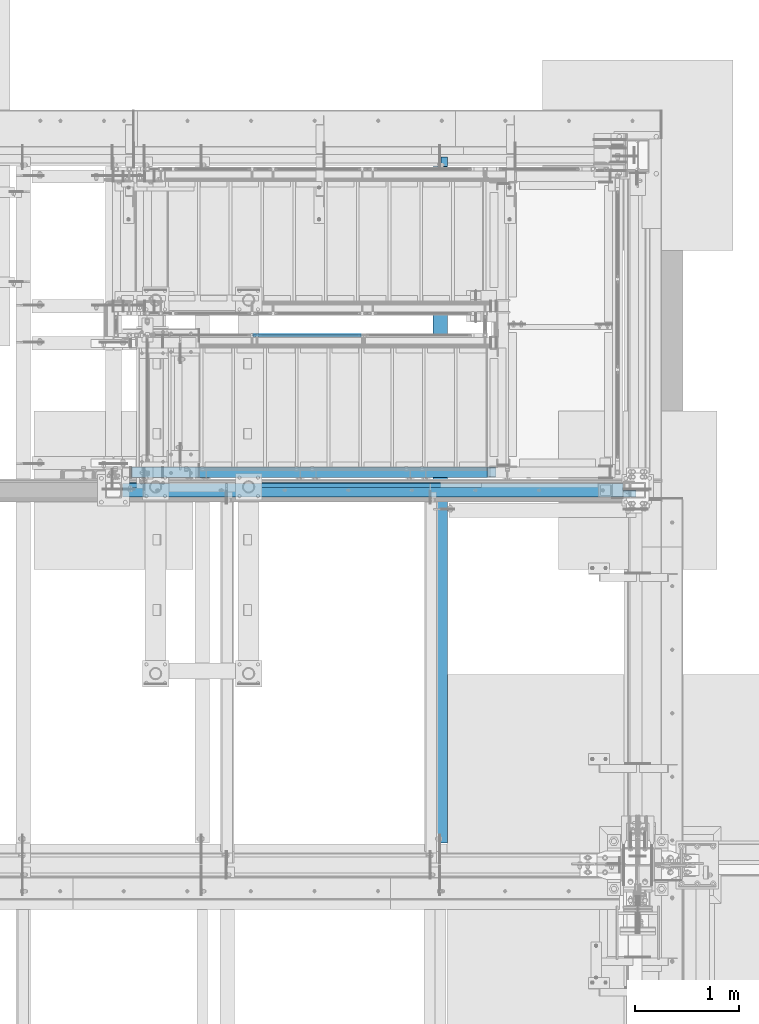
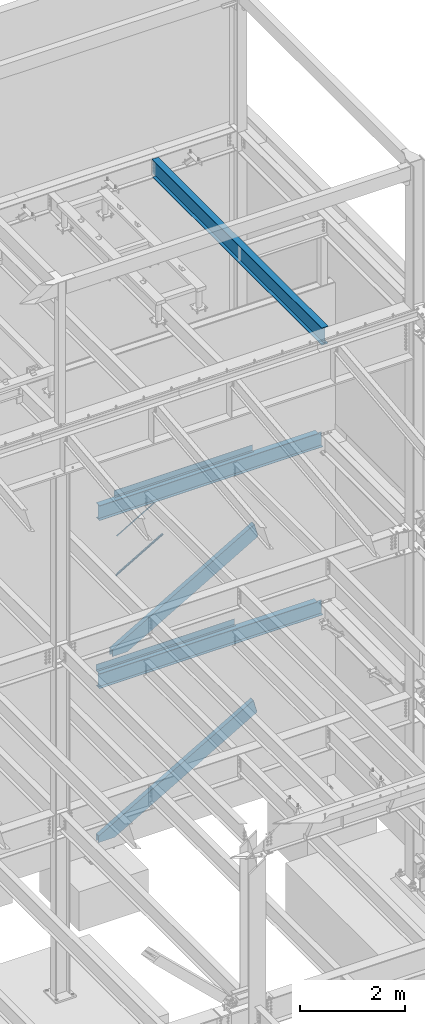
# One storey, part 782 of 1179: 7 beams, 3 members, 6 elements without a shape of their own.
"""IFC2X3 building model written with IfcOpenShell, lengths in millimetres."""

from ifc_helpers import new_model, si_unit, frame, origin_with_axes, place, context, subcontext, project, spatial, faceted_brep, material, type_object, element, aggregate, save


model = new_model("IFC2X3")

# Units and contexts
model_context = context("Model", 3, precision=1e-05, world=origin_with_axes())
body_context = subcontext(model_context, "Body", "Model", "MODEL_VIEW")
ifc_project = project(units=[si_unit("LENGTHUNIT", "METRE", prefix="MILLI"), si_unit("AREAUNIT", "SQUARE_METRE"), si_unit("VOLUMEUNIT", "CUBIC_METRE"), si_unit("MASSUNIT", "GRAM", prefix="KILO"), si_unit("TIMEUNIT", "SECOND"), si_unit("PLANEANGLEUNIT", "RADIAN"), si_unit("SOLIDANGLEUNIT", "STERADIAN"), si_unit("THERMODYNAMICTEMPERATUREUNIT", "DEGREE_CELSIUS"), si_unit("LUMINOUSINTENSITYUNIT", "LUMEN")], contexts=[model_context])

# Site, building, storey
site_placement = place(None, origin_with_axes())
site = spatial("IfcSite", under=ifc_project, at=site_placement, CompositionType="ELEMENT")
building_placement = place(site_placement, origin_with_axes())
building = spatial("IfcBuilding", under=site, at=building_placement, Name="Undefined", CompositionType="ELEMENT")
storey_placement = place(building_placement, origin_with_axes())
storey = spatial("IfcBuildingStorey", under=building, at=storey_placement, Name="Undefined", CompositionType="ELEMENT", Elevation=0.0)

# Assembly, beams, member
assembly_1_placement = place(storey_placement, origin_with_axes())
assembly_1 = element("IfcElementAssembly", 1, at=assembly_1_placement, inside=storey, Name="GUARDRAIL", AssemblyPlace="NOTDEFINED", PredefinedType="RIGID_FRAME")
ifc_material_1 = material(Name="STEEL/BUY-OUT")
beam_type_1 = type_object("IfcBeamType", PredefinedType="NOTDEFINED")
beam_1_placement = place(assembly_1_placement, frame((21150.1497940526, 39468.4251646336, 6211.04381226294), z_axis=(-0.86377890071706, 0.0, -0.503871025835012), x_axis=(-0.503871025835012, 0.0, 0.86377890071706)))
beam_1 = element("IfcBeam", 2, at=beam_1_placement, type_object=beam_type_1, material=ifc_material_1, Name="U-EDGE", context=body_context, shape_type="Brep", body=[
    faceted_brep([(-2.62571120401844e-09, 1.58750000000146, -551.090159790514), (22.2250002407682, 1.58750000000146, -589.784707497234), (22.2250002534201, 4.76249998393178, -589.784707519266), (5.1261577027617e-07, 4.76249998815911, -551.090160687567), (5.1261577027617e-07, 7.93749998815474, -551.090160687567), (25.400000253393, 7.93749998378189, -595.312499999403), (25.4000002406228, -1.58750000000146, -595.312499999232), (-2.62571120401844e-09, -1.58750000000146, -551.090159790514), (25.4000002718667, -1.58750000000146, 595.312499998905), (2.76122591458261e-09, -1.58750000000146, 580.723427522342), (2.76122591458261e-09, 1.58750000000146, 580.723427522342), (22.2250002718201, 1.58750000000146, 593.488867387849), (22.2250002590899, 4.76250001617154, 593.48886738054), (5.1151801017113e-07, 4.76250001247536, 580.723427814559), (5.1151801017113e-07, 7.93750001247827, 580.723427814559), (25.4000002590974, 7.93750001621811, 595.31249999873)], [[[0, 1, 2, 3, 4, 5, 6, 7]], [[7, 6, 8, 9]], [[0, 7, 9, 10]], [[1, 0, 10, 11]], [[2, 1, 11, 12]], [[3, 2, 12, 13]], [[4, 3, 13, 14]], [[5, 4, 14, 15]], [[6, 5, 15, 8]], [[14, 13, 12, 11, 10, 9, 8, 15]]]),
])
beam_2_placement = place(assembly_1_placement, frame((21124.5531730082, 39468.4251646336, 5346.87372905889), z_axis=(-0.86377890071706, 0.0, -0.503871025835012), x_axis=(0.503871110270223, 0.0, -0.863778851463181)))
beam_2 = element("IfcBeam", 3, at=beam_2_placement, type_object=beam_type_1, material=ifc_material_1, Name="U-EDGE", context=body_context, shape_type="Brep", body=[
    faceted_brep([(3.39150574291125e-09, 1.58750000000146, 551.090060740255), (3.39150574291125e-09, -1.58750000000146, 551.090060740255), (22.2249999259266, -1.58750000000146, 589.784086195607), (22.2249999386131, -4.76249998396088, 589.784086217693), (-1.22384335554671e-07, -4.76249998815911, 551.090060521277), (-1.22384335554671e-07, -7.93749998815474, 551.090060521277), (25.3999999386497, -7.93749998381099, 595.312500000691), (25.3999999258431, 1.58750000000146, 595.31250000052), (25.3999999312882, -7.93750001618173, -595.312500000728), (25.3999999440939, 1.58750000000146, -595.312500000899), (-3.57522367266938e-09, 1.58750000000146, -580.72370144297), (-3.57522367266938e-09, -1.58750000000146, -580.72370144297), (22.2249999440628, -1.58750000000146, -593.488900187338), (22.2249999312971, -4.76250001613516, -593.488900180007), (-1.35833943204489e-07, -4.76250001247536, -580.723701367002), (-1.35833943204489e-07, -7.93750001247827, -580.723701367002)], [[[0, 1, 2, 3, 4, 5, 6, 7]], [[7, 6, 8, 9]], [[0, 7, 9, 10]], [[1, 0, 10, 11]], [[2, 1, 11, 12]], [[3, 2, 12, 13]], [[4, 3, 13, 14]], [[5, 4, 14, 15]], [[6, 5, 15, 8]], [[14, 13, 12, 11, 10, 9, 8, 15]]]),
])
ifc_material_2 = material(Name="STEEL/A36")
member_type_1 = type_object("IfcMemberType", PredefinedType="NOTDEFINED")
member_1_placement = place(assembly_1_placement, frame((20608.9249990163, 39471.5999992249, 5006.80119240496), z_axis=(0.0, -1.0, 0.0), x_axis=(0.863778900717086, 0.0, 0.503871025834967)))
member_1 = element("IfcMember", 4, at=member_1_placement, type_object=member_type_1, material=ifc_material_2, Name="BOTTOM_RAIL", context=body_context, shape_type="Brep", body=[
    faceted_brep([(1213.01247515505, 6.34999999891988, 12.6999999999971), (1205.60414181559, -6.3500000010672, 12.6999999999971), (1205.60414181559, -6.3500000010672, -12.6999999999971), (1213.01247515505, 6.34999999891988, -12.6999999999971), (18.4069803798266, 6.34999999998945, 12.6999999999971), (18.4069803798266, 6.34999999998945, -12.6999999999971), (10.9986698027969, -6.35000000000309, -12.6999999999971), (10.9986698027969, -6.35000000000309, 12.6999999999971)], [[[0, 1, 2, 3]], [[4, 5, 6, 7]], [[5, 4, 0, 3]], [[6, 5, 3, 2]], [[7, 6, 2, 1]], [[4, 7, 1, 0]]]),
])
aggregate(assembly_1, [beam_1, beam_2, member_1])

# Assembly, beam
assembly_2_placement = place(storey_placement, origin_with_axes())
assembly_2 = element("IfcElementAssembly", 5, at=assembly_2_placement, inside=storey, Name="BEAM", AssemblyPlace="NOTDEFINED", PredefinedType="RIGID_FRAME")
beam_type_2 = type_object("IfcBeamType", PredefinedType="NOTDEFINED")
beam_3_placement = place(assembly_2_placement, frame((21285.2, 38058.725, 8147.05000610352), z_axis=(1.0, 0.0, 0.0), x_axis=(0.0, 0.0, -1.0)))
beam_3 = element("IfcBeam", 6, at=beam_3_placement, type_object=beam_type_2, material=ifc_material_2, Name="BENT_PLATE", context=body_context, shape_type="Brep", body=[
    faceted_brep([(0.0, -3.17499999999927, -1524.0), (6.00266503170133e-10, -3.17499999922438, 1524.00000000052), (6.00266503170133e-10, 3.17500000077416, 1524.00000000052), (0.0, 3.17499999999927, -1524.0), (133.350006103513, 3.17500000000291, 1524.0), (133.350006103513, 3.17500000000291, -1524.0), (127.000006103513, -3.17500000000291, -1524.0), (127.000006103513, -3.17500000000291, 1524.0), (133.350006103512, -47.6249999999927, 1524.0), (133.350006103512, -47.6249999999927, -1524.0), (127.000006103512, -47.6249999999927, 1524.0), (127.000006103512, -47.6249999999927, -1524.0)], [[[0, 1, 2, 3]], [[3, 2, 4, 5]], [[1, 0, 6, 7]], [[5, 4, 8, 9]], [[4, 2, 1, 7, 10, 8]], [[7, 6, 11, 10]], [[6, 0, 3, 5, 9, 11]], [[10, 11, 9, 8]]]),
])

assembly_3_placement = place(storey_placement, origin_with_axes())
assembly_3 = element("IfcElementAssembly", 7, at=assembly_3_placement, inside=storey, Name="BEAM", AssemblyPlace="NOTDEFINED", PredefinedType="RIGID_FRAME")
beam_4_placement = place(assembly_3_placement, frame((20891.5, 38058.725, 4235.45000610352), z_axis=(1.0, 0.0, 0.0), x_axis=(0.0, 0.0, -1.0)))
beam_4 = element("IfcBeam", 8, at=beam_4_placement, type_object=beam_type_2, material=ifc_material_2, Name="BENT_PLATE", context=body_context, shape_type="Brep", body=[
    faceted_brep([(0.0, -3.17499999999927, -1524.0), (6.00266503170133e-10, -3.17499999922438, 1524.00000000052), (6.00266503170133e-10, 3.17500000077416, 1524.00000000052), (0.0, 3.17499999999927, -1524.0), (133.350006103513, 3.17500000000291, 1524.0), (133.350006103513, 3.17500000000291, -1524.0), (127.000006103513, -3.17500000000291, -1524.0), (127.000006103513, -3.17500000000291, 1524.0), (133.350006103512, -47.6249999999927, 1524.0), (133.350006103512, -47.6249999999927, -1524.0), (127.000006103512, -47.6249999999927, 1524.0), (127.000006103512, -47.6249999999927, -1524.0)], [[[0, 1, 2, 3]], [[3, 2, 4, 5]], [[1, 0, 6, 7]], [[5, 4, 8, 9]], [[4, 2, 1, 7, 10, 8]], [[7, 6, 11, 10]], [[6, 0, 3, 5, 9, 11]], [[10, 11, 9, 8]]]),
])

# Beam
ifc_material_3 = material(Name="STEEL/A992")
beam_type_3 = type_object("IfcBeamType", Name="W14X22", PredefinedType="NOTDEFINED")
beam_5_placement = place(assembly_2_placement, frame((19278.6, 37985.7, 7839.075), z_axis=(0.0, 0.0, 1.0), x_axis=(1.0, 0.0, 0.0)))
beam_5 = element("IfcBeam", 9, at=beam_5_placement, type_object=beam_type_3, material=ifc_material_3, Name="BEAM", ObjectType="W14X22", context=body_context, shape_type="Brep", body=[
    faceted_brep([(4909.34375, -63.5, 174.625), (4909.34375, -63.5, 166.6875), (4909.34375, -3.17500000000291, 166.6875), (4909.34375, -3.17500000000291, 155.574999809264), (4909.34375, 3.17500000000291, 155.574999809264), (4909.34375, 3.17500000000291, 166.6875), (4909.34375, 63.5, 166.6875), (4909.34375, 63.5, 174.625), (4910.31047992258, -3.17500000000291, 150.714920291219), (4910.31047992258, 3.17500000000291, 150.714920291219), (4913.06349382306, -3.17500000000291, 146.594743823065), (4913.06349382306, 3.17500000000291, 146.594743823065), (4917.18367029122, -3.17500000000291, 143.841729922587), (4917.18367029122, 3.17500000000291, 143.841729922587), (4922.04374980926, -3.17500000000291, 142.874999999999), (4922.04374980926, 3.17500000000291, 142.874999999999), (5010.94375, -3.17500000000291, 142.874999999999), (5010.94375, 3.17500000000291, 142.874999999999), (88.9000000000015, -63.5, -174.625), (88.9000000000015, -63.5, -166.6875), (88.9000000000015, -3.17500000000291, -166.6875), (88.9000000000015, -3.17500000000291, 166.6875), (88.9000000000015, -63.5, 166.6875), (88.9000000000015, -63.5, 174.625), (88.9000000000015, 63.5, 174.625), (88.9000000000015, 63.5, 166.6875), (88.9000000000015, 3.17500000000291, 166.6875), (88.9000000000015, 3.17500000000291, -166.6875), (88.9000000000015, 63.5, -166.6875), (88.9000000000015, 63.5, -174.625), (4883.94375, 3.17500000000291, -166.6875), (4883.94375, 63.5, -166.6875), (4883.94375, 63.5, -174.625), (4883.94375, 3.17549991607666, -174.625), (5010.94375, 3.17500000000291, -166.6875), (5010.94375, 3.17549991607666, -174.625), (5010.94375, -63.5, -174.625), (5010.94375, -63.5, -166.6875), (5010.94375, -3.17500000000291, -166.6875)], [[[0, 1, 2, 3, 4, 5, 6, 7]], [[8, 9, 4, 3]], [[10, 11, 9, 8]], [[12, 13, 11, 10]], [[14, 15, 13, 12]], [[16, 17, 15, 14]], [[18, 19, 20, 21, 22, 23, 24, 25, 26, 27, 28, 29]], [[28, 27, 30, 31]], [[29, 28, 31, 32]], [[30, 33, 32, 31]], [[34, 35, 33, 30]], [[36, 18, 29, 32, 33, 35]], [[19, 18, 36, 37]], [[20, 19, 37, 38]], [[12, 10, 8, 3, 2, 21, 20, 38, 16, 14]], [[22, 21, 2, 1]], [[23, 22, 1, 0]], [[24, 23, 0, 7]], [[25, 24, 7, 6]], [[26, 25, 6, 5]], [[34, 30, 27, 26, 5, 4, 9, 11, 13, 15, 17]], [[38, 37, 36, 35, 34, 17, 16]]]),
])

aggregate(assembly_2, [beam_3, beam_5])

beam_6_placement = place(assembly_3_placement, frame((19278.6, 37985.7, 3927.475), z_axis=(0.0, 0.0, 1.0), x_axis=(1.0, 0.0, 0.0)))
beam_6 = element("IfcBeam", 10, at=beam_6_placement, type_object=beam_type_3, material=ifc_material_3, Name="BEAM", ObjectType="W14X22", context=body_context, shape_type="Brep", body=[
    faceted_brep([(4887.11875, -63.5, 174.625), (4887.11875, -63.5, 166.6875), (4887.11875, -3.17500000000291, 166.6875), (4887.11875, -3.17500000000291, 155.574999809265), (4887.11875, 3.17500000000291, 155.574999809265), (4887.11875, 3.17500000000291, 166.6875), (4887.11875, 63.5, 166.6875), (4887.11875, 63.5, 174.625), (4888.08547992259, -3.17500000000291, 150.714920291219), (4888.08547992259, 3.17500000000291, 150.714920291219), (4890.83849382306, -3.17500000000291, 146.594743823066), (4890.83849382306, 3.17500000000291, 146.594743823066), (4894.95867029122, -3.17500000000291, 143.841729922588), (4894.95867029122, 3.17500000000291, 143.841729922588), (4899.81874980926, -3.17500000000291, 142.875), (4899.81874980926, 3.17500000000291, 142.875), (5010.94375, -3.17500000000291, 142.874999999999), (5010.94375, 3.17500000000291, 142.874999999999), (88.9000000000015, -63.5, -174.625), (88.9000000000015, -63.5, -166.6875), (88.9000000000015, -3.17500000000291, -166.6875), (88.9000000000015, -3.17500000000291, 166.6875), (88.9000000000015, -63.5, 166.6875), (88.9000000000015, -63.5, 174.625), (88.9000000000015, 63.5, 174.625), (88.9000000000015, 63.5, 166.6875), (88.9000000000015, 3.17500000000291, 166.6875), (88.9000000000015, 3.17500000000291, -166.6875), (88.9000000000015, 63.5, -166.6875), (88.9000000000015, 63.5, -174.625), (4883.94375, 3.17500000000291, -166.6875), (4883.94375, 63.5, -166.6875), (4883.94375, 63.5, -174.625), (4883.94375, 3.17549991607666, -174.625), (5010.94375, 3.17500000000291, -166.6875), (5010.94375, 3.17549991607666, -174.625), (5010.94375, -63.5, -174.625), (5010.94375, -63.5, -166.6875), (5010.94375, -3.17500000000291, -166.6875)], [[[0, 1, 2, 3, 4, 5, 6, 7]], [[8, 9, 4, 3]], [[10, 11, 9, 8]], [[12, 13, 11, 10]], [[14, 15, 13, 12]], [[16, 17, 15, 14]], [[18, 19, 20, 21, 22, 23, 24, 25, 26, 27, 28, 29]], [[28, 27, 30, 31]], [[29, 28, 31, 32]], [[30, 33, 32, 31]], [[34, 35, 33, 30]], [[36, 18, 29, 32, 33, 35]], [[19, 18, 36, 37]], [[20, 19, 37, 38]], [[12, 10, 8, 3, 2, 21, 20, 38, 16, 14]], [[22, 21, 2, 1]], [[23, 22, 1, 0]], [[24, 23, 0, 7]], [[25, 24, 7, 6]], [[26, 25, 6, 5]], [[34, 30, 27, 26, 5, 4, 9, 11, 13, 15, 17]], [[38, 37, 36, 35, 34, 17, 16]]]),
])

aggregate(assembly_3, [beam_4, beam_6])

# Assembly, beam
assembly_4_placement = place(storey_placement, origin_with_axes())
assembly_4 = element("IfcElementAssembly", 11, at=assembly_4_placement, inside=storey, Name="BEAM", AssemblyPlace="NOTDEFINED", PredefinedType="RIGID_FRAME")
beam_type_4 = type_object("IfcBeamType", Name="W16X31", PredefinedType="NOTDEFINED")
beam_7_placement = place(assembly_4_placement, frame((22415.5, 34391.6, 12917.4875), z_axis=(0.0, 0.0, 1.0), x_axis=(0.0, 1.0, 0.0)))
beam_7 = element("IfcBeam", 12, at=beam_7_placement, type_object=beam_type_4, material=ifc_material_3, Name="BEAM", ObjectType="W16X31", context=body_context, shape_type="Brep", body=[
    faceted_brep([(212.724999999999, 69.8499999999985, -190.5), (212.724999999999, 3.17499999999927, -190.5), (6661.94375000001, 3.17499999999927, -190.5), (6661.94375000001, 69.8499999999985, -190.5), (212.724999999999, -3.17499999999927, -190.5), (212.724999999999, -69.8499999999985, -190.5), (6788.94375000001, -69.8499999999985, -190.5), (6788.94375000001, -3.17499999999927, -190.5), (212.724999999999, -69.8499999999985, -201.612499999999), (6788.94375000001, -69.8499999999985, -201.612499999999), (6788.94375000001, 3.17549991607666, -201.612499999999), (6788.94375000001, 3.17499999999927, -190.5), (6788.94375000001, 3.17499999999927, 163.512499999999), (6788.94375000001, -3.17499999999927, 163.512499999999), (6661.94375000001, 3.17549991607666, -201.612499999999), (212.724999999999, 69.8499999999985, -201.612499999999), (6661.94375000001, 69.8499999999985, -201.612499999999), (212.724999999999, -3.17499999999927, 190.5), (212.724999999999, -69.8499999999985, 190.5), (212.724999999999, -69.8499999999985, 201.612499999999), (212.724999999999, 69.8499999999985, 201.612499999999), (212.724999999999, 69.8499999999985, 190.5), (212.724999999999, 3.17499999999927, 190.5), (212.724999999999, 3.17499999999927, 162.664998864024), (212.724999999999, 3.17499999999927, -142.027500567505), (6696.86875000001, 69.8499999999985, 190.5), (6696.86875000001, 3.17499999999927, 190.5), (6696.86875000001, 3.17499999999927, 176.212499809264), (6697.8354799226, 3.17499999999927, 171.352420291218), (6700.58849382307, 3.17499999999927, 167.232243823064), (6704.70867029123, 3.17499999999927, 164.479229922586), (6709.56874980927, 3.17499999999927, 163.512499999999), (6697.8354799226, -3.17499999999927, 171.352420291218), (6696.86875000001, -3.17499999999927, 176.212499809264), (6700.58849382307, -3.17499999999927, 167.232243823064), (6704.70867029123, -3.17499999999927, 164.479229922586), (6709.56874980927, -3.17499999999927, 163.512499999999), (6696.86875000001, -3.17499999999927, 190.5), (6696.86875000001, -69.8499999999985, 190.5), (6696.86875000001, -69.8499999999985, 201.612499999999), (6696.86875000001, 69.8499999999985, 201.612499999999)], [[[0, 1, 2, 3]], [[4, 5, 6, 7]], [[5, 8, 9, 6]], [[7, 6, 9, 10, 11, 12, 13]], [[11, 10, 14, 2]], [[9, 8, 15, 16, 14, 10]], [[2, 14, 16, 3]], [[15, 0, 3, 16]], [[8, 5, 4, 17, 18, 19, 20, 21, 22, 23, 24, 1, 0, 15]], [[22, 21, 25, 26]], [[11, 2, 1, 24, 23, 22, 26, 27, 28, 29, 30, 31, 12]], [[32, 28, 27, 33]], [[34, 29, 28, 32]], [[35, 30, 29, 34]], [[36, 31, 30, 35]], [[13, 12, 31, 36]], [[35, 34, 32, 33, 37, 17, 4, 7, 13, 36]], [[18, 17, 37, 38]], [[19, 18, 38, 39]], [[20, 19, 39, 40]], [[21, 20, 40, 25]], [[39, 38, 37, 33, 27, 26, 25, 40]]]),
])
aggregate(assembly_4, [beam_7])

# Assembly, member
assembly_5_placement = place(storey_placement, origin_with_axes())
assembly_5 = element("IfcElementAssembly", 13, at=assembly_5_placement, inside=storey, Name="STAIR", AssemblyPlace="NOTDEFINED", PredefinedType="RIGID_FRAME")
ifc_material_4 = material()
member_type_2 = type_object("IfcMemberType", Name="HSS12X4X3/8", PredefinedType="NOTDEFINED")
member_2_placement = place(assembly_5_placement, frame((19657.8587906339, 38157.1499999754, 4180.01009550552), z_axis=(-0.503871025835012, 0.0, 0.86377890071706), x_axis=(0.863778900717086, 0.0, 0.503871025834967)))
member_2 = element("IfcMember", 14, at=member_2_placement, type_object=member_type_2, material=ifc_material_4, Name="STAIR", ObjectType="HSS12X4X3/8", context=body_context, shape_type="Brep", body=[
    faceted_brep([(373.860185462025, -41.2750000000015, -142.875000000266), (390.188756877178, -41.2750000000015, -152.400000000276), (409.092403865525, -50.8000000000029, -152.400000000293), (121.312264914868, -50.8000000000029, 15.4717478590865), (116.512893393778, -41.2750000000015, 7.24425382976369), (409.092403865525, 50.8000000000029, -152.400000000293), (390.188756877178, 41.2750000000015, -152.400000000276), (373.860185462025, 41.2750000000015, -142.875000000266), (116.512893393778, 41.2750000000015, 7.24425382976369), (121.312264914868, 50.8000000000029, 15.4717478590865), (3828.56404744801, -41.2750000000015, 142.87499999654), (3821.27217623257, -50.8000000000029, 152.399999996541), (3738.86975779834, -50.8000000000029, -152.400000003247), (3751.31178016953, -41.2750000000015, -142.875000003263), (3751.31178016953, 41.2750000000015, -142.875000003263), (3738.86975779834, 50.8000000000029, -152.400000003247), (3821.27217623257, 50.8000000000029, 152.399999996541), (3828.56404744801, 41.2750000000015, 142.87499999654), (195.630828725345, -41.2750000000015, 142.874999999765), (195.630828725345, 41.2750000000015, 142.874999999765), (201.187078729952, 50.8000000000029, 152.399999999756), (201.187078729952, -50.8000000000029, 152.399999999756)], [[[0, 1, 2, 3, 4]], [[5, 6, 7, 8, 9]], [[10, 11, 12, 13]], [[14, 15, 16, 17]], [[15, 14, 13, 12]], [[18, 19, 17, 10]], [[20, 21, 11, 16]], [[17, 16, 11, 10]], [[7, 0, 13, 14]], [[18, 10, 13, 0, 4]], [[21, 20, 9, 8, 19, 18, 4, 3]], [[7, 6, 1, 0]], [[14, 17, 19, 8, 7]], [[20, 16, 15, 5, 9]], [[6, 5, 15, 12, 2, 1]], [[12, 11, 21, 3, 2]]]),
])
aggregate(assembly_5, [member_2])

assembly_6_placement = place(storey_placement, origin_with_axes())
assembly_6 = element("IfcElementAssembly", 15, at=assembly_6_placement, inside=storey, Name="STAIR", AssemblyPlace="NOTDEFINED", PredefinedType="RIGID_FRAME")
member_3_placement = place(assembly_6_placement, frame((19353.3283000728, 38157.1500000129, -55.6883530876565), z_axis=(-0.501065882891504, 0.0, 0.86540914081269), x_axis=(0.86540914081267, 0.0, 0.501065882891537)))
member_3 = element("IfcMember", 16, at=member_3_placement, type_object=member_type_2, material=ifc_material_4, Name="STAIR", ObjectType="HSS12X4X3/8", context=body_context, shape_type="Brep", body=[
    faceted_brep([(4140.53967882592, 50.8000000000029, 152.399999998357), (4147.84381136938, 41.2750000000015, 142.874999998361), (4071.08875896335, 41.2750000000015, -142.87500000147), (4058.66762287847, 50.8000000000029, -152.40000000146), (4058.66762287847, -50.799999963645, -152.400000085589), (4071.08875896335, -41.2750000000015, -142.87500000147), (4147.84381136938, -41.2750000000015, 142.874999998361), (4140.53967882592, -50.8000000000029, 152.399999998368), (437.852816707822, 50.8000000000029, -152.400000000091), (402.392275589955, 41.2750000000015, -142.875000000084), (122.776731403286, 41.2750000000015, 19.0202638400478), (127.54938393784, 50.8000000000029, 27.2632859062833), (402.392275589955, -41.2750000000015, -142.875000000084), (437.852816707818, -50.7999866158716, -152.4000309701), (127.549383852154, -50.8000000000029, 27.2632857582921), (122.776731403286, -41.2750000000015, 19.0202638400478), (194.487763558682, -41.2750000000015, 142.874999999854), (194.487763558682, 41.2750000000015, 142.874999999854), (211.009027155058, 50.8000000000029, 152.399999999845), (211.009027155058, -50.8000000000029, 152.40000000416), (194.487763559555, -50.8000000000029, 142.875000001359), (194.487763559555, 50.8000000000029, 142.875000001359)], [[[0, 1, 2, 3]], [[4, 5, 6, 7]], [[8, 9, 10, 11]], [[12, 13, 14, 15]], [[5, 4, 3, 2]], [[16, 17, 1, 6]], [[18, 19, 7, 0]], [[7, 6, 1, 0]], [[6, 5, 12, 15, 16]], [[9, 12, 5, 2]], [[13, 12, 9, 8]], [[20, 16, 15, 14]], [[19, 18, 21, 17, 16, 20]], [[17, 21, 11, 10]], [[9, 2, 1, 17, 10]], [[8, 11, 21, 18, 0, 3]], [[13, 8, 3, 4]], [[19, 20, 14, 13, 4, 7]]]),
])
aggregate(assembly_6, [member_3])

save(model, "model.ifc")
